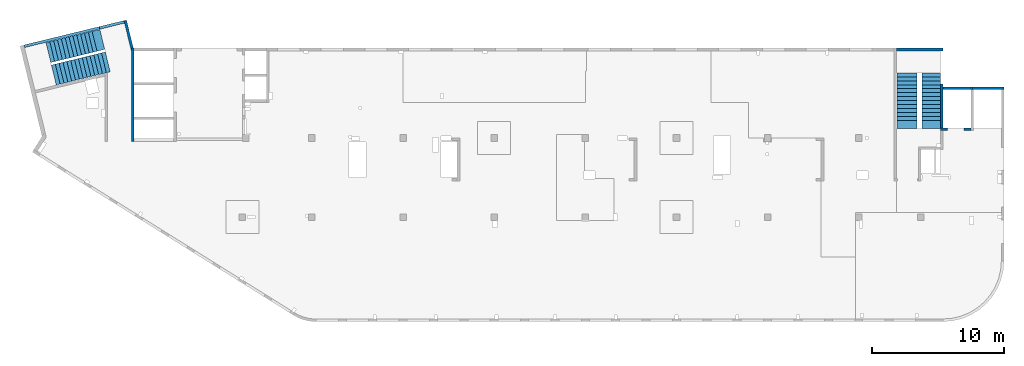
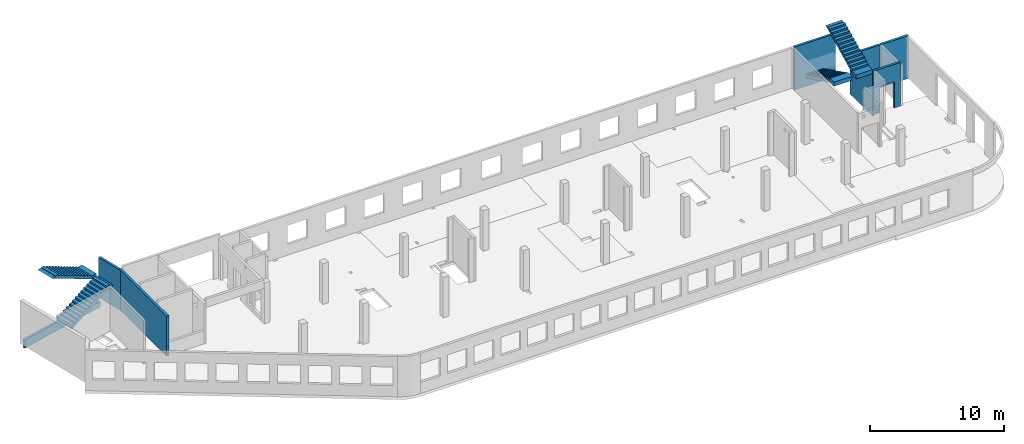
# One storey, part 3 of 6: 8 walls, 4 stairs, 3 openings.
"""IFC4 building model written with IfcOpenShell, lengths in millimetres."""

from ifc_helpers import new_model, entity, si_unit, converted_unit, derived_unit, direction, frame, origin, place, context, subcontext, project, spatial, indexed_curve, outline, extrude, polygons, material, type_object, element, save


model = new_model("IFC4")

# Units and contexts
model_context = context("Model", 3, precision=0.01, world=origin(), true_north=direction((6.12303176911189e-17, 1.0)))
plan_context = context("Plan", 3, precision=0.01, world=origin(), true_north=direction((6.12303176911189e-17, 1.0)))
body_context = subcontext(model_context, "Body", "Model", "MODEL_VIEW")
ifc_project = project(units=[si_unit("LENGTHUNIT", "METRE", prefix="MILLI"), si_unit("AREAUNIT", "SQUARE_METRE"), si_unit("VOLUMEUNIT", "CUBIC_METRE"), converted_unit("PLANEANGLEUNIT", "DEGREE", entity("IfcRatioMeasure", 0.0174532925199433), si_unit("PLANEANGLEUNIT", "RADIAN"), dimensions=[0, 0, 0, 0, 0, 0, 0]), si_unit("MASSUNIT", "GRAM", prefix="KILO"), derived_unit("MASSDENSITYUNIT", [(si_unit("MASSUNIT", "GRAM", prefix="KILO"), 1), (si_unit("LENGTHUNIT", "METRE"), -3)]), derived_unit("MOMENTOFINERTIAUNIT", [(si_unit("LENGTHUNIT", "METRE"), 4)]), si_unit("TIMEUNIT", "SECOND"), si_unit("FREQUENCYUNIT", "HERTZ"), si_unit("THERMODYNAMICTEMPERATUREUNIT", "DEGREE_CELSIUS"), derived_unit("THERMALTRANSMITTANCEUNIT", [(si_unit("MASSUNIT", "GRAM", prefix="KILO"), 1), (si_unit("THERMODYNAMICTEMPERATUREUNIT", "KELVIN"), -1), (si_unit("TIMEUNIT", "SECOND"), -3)]), derived_unit("VOLUMETRICFLOWRATEUNIT", [(si_unit("LENGTHUNIT", "METRE"), 3), (si_unit("TIMEUNIT", "SECOND"), -1)]), derived_unit("MASSFLOWRATEUNIT", [(si_unit("MASSUNIT", "GRAM", prefix="KILO"), 1), (si_unit("TIMEUNIT", "SECOND"), -1)]), derived_unit("ROTATIONALFREQUENCYUNIT", [(si_unit("TIMEUNIT", "SECOND"), -1)]), si_unit("ELECTRICCURRENTUNIT", "AMPERE"), si_unit("ELECTRICVOLTAGEUNIT", "VOLT"), si_unit("POWERUNIT", "WATT"), si_unit("FORCEUNIT", "NEWTON", prefix="KILO"), si_unit("ILLUMINANCEUNIT", "LUX"), si_unit("LUMINOUSFLUXUNIT", "LUMEN"), si_unit("LUMINOUSINTENSITYUNIT", "CANDELA"), derived_unit("USERDEFINED", [(si_unit("MASSUNIT", "GRAM", prefix="KILO"), -1), (si_unit("LENGTHUNIT", "METRE"), -2), (si_unit("TIMEUNIT", "SECOND"), 3), (si_unit("LUMINOUSFLUXUNIT", "LUMEN"), 1)]), derived_unit("LINEARVELOCITYUNIT", [(si_unit("LENGTHUNIT", "METRE"), 1), (si_unit("TIMEUNIT", "SECOND"), -1)]), si_unit("PRESSUREUNIT", "PASCAL"), derived_unit("USERDEFINED", [(si_unit("LENGTHUNIT", "METRE"), -2), (si_unit("MASSUNIT", "GRAM", prefix="KILO"), 1), (si_unit("TIMEUNIT", "SECOND"), -2)]), derived_unit("LINEARFORCEUNIT", [(si_unit("MASSUNIT", "GRAM", prefix="KILO"), 1), (si_unit("LENGTHUNIT", "METRE"), 1), (si_unit("TIMEUNIT", "SECOND"), -2), (si_unit("LENGTHUNIT", "METRE"), -1)]), derived_unit("PLANARFORCEUNIT", [(si_unit("MASSUNIT", "GRAM", prefix="KILO"), 1), (si_unit("LENGTHUNIT", "METRE"), 1), (si_unit("TIMEUNIT", "SECOND"), -2), (si_unit("LENGTHUNIT", "METRE"), -2)])], contexts=[model_context, plan_context])

# Site, building, storey
site_placement = place(None, origin())
site = spatial("IfcSite", under=ifc_project, at=site_placement, CompositionType="ELEMENT")
building_placement = place(site_placement, origin())
building = spatial("IfcBuilding", under=site, at=building_placement, CompositionType="ELEMENT")
storey_placement = place(building_placement, frame((0.0, 0.0, 8100.0)))
storey = spatial("IfcBuildingStorey", under=building, at=storey_placement, CompositionType="ELEMENT", Elevation=8100.0)

# Wall
ifc_material_1 = material()
wall_type = type_object("IfcWallType", PredefinedType="STANDARD")
wall_1_placement = place(storey_placement, frame((71069.9994506836, 17469.9992263555, -400.0)))
element("IfcWall", 1, at=wall_1_placement, inside=storey, type_object=wall_type, material=ifc_material_1, PredefinedType="NOTDEFINED", context=body_context, shape_type="SweptSolid", body=[
    extrude(outline(indexed_curve([(2500.0008178711, -99.9999999999999), (2500.0008178711, 100.0), (99.9999999999943, 99.9999999999992), (99.9999999999949, -100.000000000001), (2500.0008178711, -99.9999999999999)], self_intersect=False)), origin(), (0.0, 0.0, 1.0), 3900.0),
])

# Wall, opening
wall_2_placement = place(storey_placement, frame((71069.9994506836, 14369.9992263555, -150.0), z_axis=(0.0, 0.0, 1.0), x_axis=(-1.0, 0.0, 0.0)))
wall_2 = element("IfcWall", 2, at=wall_2_placement, inside=storey, type_object=wall_type, material=ifc_material_1, PredefinedType="NOTDEFINED", context=body_context, shape_type="Tessellation", body=[
    polygons([(2299.99918212887, -100.000000000003, 3950.0), (2099.99918212887, -100.000000000001, 3950.0), (-2.4387927500343e-12, -100.000000000001, 3950.0), (-2.4387927500343e-12, -100.000000000001, 0.0), (529.999182128873, -100.000000000001, 0.0), (529.999182128864, -100.000000000001, 2369.99999999805), (1769.99918212887, -99.9999999999989, 2369.99999999804), (1769.99918212887, -99.9999999999989, 0.0), (2299.99918212887, -100.000000000003, 0.0), (2299.99918212887, -100.000000000001, 3650.0), (-3.00376710535355e-12, 99.9999999999968, 3950.0), (2099.99918212887, 99.9999999999989, 3950.0), (2299.99918212887, 99.9999999999989, 3950.0), (2299.99918212887, 99.9999999999989, 3900.0), (2299.99918212887, 99.9999999999989, 0.0), (2099.99918212887, 99.9999999999989, 0.0), (1769.99918212887, 99.9999999999989, 0.0), (1769.99918212887, 99.9999999999989, 2369.99999999805), (529.999182128872, 99.9999999999989, 2369.99999999805), (529.999182128872, 99.9999999999989, 0.0), (-3.00376710535355e-12, 99.9999999999968, 0.0), (-3.00376710535355e-12, 99.9999999999989, 3650.0)], [[[1, 2, 3, 4, 5, 6, 7, 8, 9, 10]], [[11, 12, 13, 14, 15, 16, 17, 18, 19, 20, 21, 22]], [[4, 21, 20, 5]], [[3, 2, 1, 13, 12, 11]], [[4, 3, 11, 22, 21]], [[6, 19, 18, 7]], [[7, 18, 17, 8]], [[19, 6, 5, 20]], [[9, 15, 14, 13, 1, 10]], [[15, 9, 8, 17, 16]]], closed=True),
])
opening_1_placement = place(wall_2_placement, frame((71069.9994506836, 14369.9992263555, 150.0), z_axis=(0.0, 0.0, 1.0), x_axis=(-1.0, 0.0, 0.0)))
element("IfcOpeningElement", 3, at=opening_1_placement, cuts=wall_2, PredefinedType="OPENING", context=body_context, shape_type="SweptSolid", body=[
    extrude(outline(indexed_curve([(-619.999999999998, -1184.99999999902), (620.000000000006, -1184.99999999902), (620.000000000006, 1184.99999999902), (-619.999999999998, 1184.99999999902), (-619.999999999998, -1184.99999999902)], self_intersect=False)), frame((69920.0002685547, 14569.9992263574, 1035.0), z_axis=(0.0, -1.0, 0.0), x_axis=(-1.0, 0.0, 0.0)), (0.0, 0.0, 1.0), 400.000000001943),
])

# Wall, openings
wall_3_placement = place(storey_placement, frame((7600.0002685547, 20499.9998657227, -150.0), z_axis=(0.0, 0.0, 1.0), x_axis=(0.0, -1.0, 0.0)))
wall_3 = element("IfcWall", 4, at=wall_3_placement, inside=storey, type_object=wall_type, material=ifc_material_1, PredefinedType="NOTDEFINED", context=body_context, shape_type="Tessellation", body=[
    polygons([(0.0, -100.000000000001, 0.0), (226.50010582161, -99.9999999999996, 0.0), (7050.0006393668, -99.9999999999996, 0.0), (7050.0006393668, -99.9999999999996, 3650.0), (226.500105821614, -99.9999999999996, 3650.0), (0.0, -100.000000000001, 3650.0), (0.0, 100.0, 0.0), (0.0, 100.0, 3650.0), (200.000000000002, 100.0, 3650.0), (6850.0006393668, 100.0, 3650.0), (7050.0006393668, 99.9999999999993, 3650.0), (7050.0006393668, 100.0, 1200.0), (7050.0006393668, 99.9999999999993, 0.0), (6850.0006393668, 100.0, 0.0), (0.0, 50.6443876577722, 0.0), (0.0, 50.6443876577722, 3650.0), (0.0, 7.9044633377313e-14, 3650.0)], [[[1, 2, 3, 4, 5, 6]], [[7, 8, 9, 10, 11, 12, 13, 14]], [[3, 2, 1, 15, 7, 14, 13]], [[6, 5, 4, 11, 10, 9, 8, 16, 17]], [[1, 6, 17, 16, 8, 7, 15]], [[4, 3, 13, 12, 11]]], closed=True),
])
opening_2_placement = place(wall_3_placement, frame((20499.9998657227, -7600.0002685547, 150.0), z_axis=(0.0, 0.0, 1.0), x_axis=(0.0, 1.0, 0.0)))
element("IfcOpeningElement", 5, at=opening_2_placement, cuts=wall_3, PredefinedType="OPENING", context=body_context, shape_type="SweptSolid", body=[
    extrude(outline(indexed_curve([(-154.999999999993, -154.999999999999), (154.999999999993, -154.999999999999), (154.999999999993, 154.999999999999), (-154.999999999993, 154.999999999999), (-154.999999999993, -154.999999999999)], self_intersect=False)), frame((7500.00026855469, 14359.9998657227, 3655.0), z_axis=(1.0, 0.0, 0.0), x_axis=(0.0, 0.0, -1.0)), (0.0, 0.0, 1.0), 200.000000000962),
])
opening_3_placement = place(wall_3_placement, frame((20499.9998657227, -7600.0002685547, 150.0), z_axis=(0.0, 0.0, 1.0), x_axis=(0.0, 1.0, 0.0)))
element("IfcOpeningElement", 6, at=opening_3_placement, cuts=wall_3, PredefinedType="OPENING", context=body_context, shape_type="SweptSolid", body=[
    extrude(outline(indexed_curve([(-154.999999999993, -154.999999999999), (154.999999999993, -154.999999999999), (154.999999999993, 154.999999999999), (-154.999999999993, 154.999999999999), (-154.999999999993, -154.999999999999)], self_intersect=False)), frame((7500.00026855469, 14799.9998657227, 3655.0), z_axis=(1.0, 0.0, 0.0), x_axis=(0.0, 0.0, -1.0)), (0.0, 0.0, 1.0), 200.000000000962),
])

# Walls
wall_4_placement = place(storey_placement, frame((68870.0002685547, 17779.9992263555, -400.0), z_axis=(0.0, 0.0, 1.0), x_axis=(0.0, -1.0, 0.0)))
element("IfcWall", 7, at=wall_4_placement, inside=storey, type_object=wall_type, material=ifc_material_1, PredefinedType="NOTDEFINED", context=body_context, shape_type="Tessellation", body=[
    polygons([(2.16573425859679e-12, -99.9999999999946, 0.0), (3310.0, -99.9999999999946, 0.0), (3310.0, -99.9999999999946, 249.999999999999), (3310.0, -99.9999999999946, 3900.0), (2.16573425859679e-12, -99.9999999999946, 3900.0), (3310.0, 100.000000000012, 0.0), (410.0, 100.000000000003, 0.0), (210.0, 100.000000000003, 0.0), (2.16573425859679e-12, 100.000000000012, 0.0), (2.16573425859679e-12, 100.000000000012, 3900.0), (3310.0, 100.000000000012, 3900.0)], [[[1, 2, 3, 4, 5]], [[6, 7, 8, 9, 10, 11]], [[2, 1, 9, 8, 7, 6]], [[9, 1, 5, 10]], [[2, 6, 11, 4, 3]], [[5, 4, 11, 10]]], closed=True),
])
wall_5_placement = place(storey_placement, frame((68970.0002685547, 17469.9992263555, -400.0)))
element("IfcWall", 8, at=wall_5_placement, inside=storey, type_object=wall_type, material=ifc_material_1, PredefinedType="NOTDEFINED", context=body_context, shape_type="Tessellation", body=[
    polygons([(6.89939203009021e-12, -100.000000000001, 0.0), (2199.99918212887, -100.000000000001, 0.0), (2199.99918212887, -100.000000000001, 249.999999999999), (2099.99918212888, -100.000000000001, 249.999999999999), (2099.99918212888, -100.000000000001, 3900.0), (6.89939203009021e-12, -100.000000000001, 3900.0), (2199.99918212887, 99.9999999999989, 0.0), (6.28061057235613e-12, 99.9999999999989, 0.0), (6.28061057235613e-12, 99.9999999999989, 3900.0), (2099.99918212888, 99.9999999999989, 3900.0), (2099.99918212888, 99.9999999999989, 249.999999999999), (2199.99918212887, 99.9999999999989, 249.999999999999)], [[[1, 2, 3, 4, 5, 6]], [[7, 8, 9, 10, 11, 12]], [[2, 1, 8, 7]], [[2, 7, 12, 3]], [[5, 4, 11, 10]], [[8, 1, 6, 9]], [[4, 3, 12, 11]], [[6, 5, 10, 9]]], closed=True),
])
wall_6_placement = place(storey_placement, frame((65430.0002685547, 20399.9998657227, -400.0)))
element("IfcWall", 9, at=wall_6_placement, inside=storey, type_object=wall_type, material=ifc_material_1, PredefinedType="NOTDEFINED", context=body_context, shape_type="SweptSolid", body=[
    extrude(outline(indexed_curve([(3539.99999999995, 99.9999999999989), (-3.67073603151997e-13, 99.9999999999989), (3.67073603151997e-13, -99.9999999999989), (3539.99999999995, -99.9999999999989), (3539.99999999995, 99.9999999999989)], self_intersect=False)), origin(), (0.0, 0.0, 1.0), 3900.0),
])
wall_7_placement = place(storey_placement, frame((7033.44218130896, 22609.751914045, -150.0), z_axis=(0.0, 0.0, 1.0), x_axis=(0.236826092990328, -0.971552058141475, 0.0)))
element("IfcWall", 10, at=wall_7_placement, inside=storey, type_object=wall_type, material=ifc_material_1, PredefinedType="NOTDEFINED", context=body_context, shape_type="Tessellation", body=[
    polygons([(-4.33146851719357e-12, -99.9999999999989, 0.0), (2380.28371765147, -99.9999999999995, 0.0), (2380.28371765147, -100.000000000001, 3650.0), (199.999999999998, -100.0, 3650.0), (-4.33146851719357e-12, -99.9999999999989, 3650.0), (-4.33146851719357e-12, -99.9999999999989, 3150.0), (-4.33146851719357e-12, 100.0, 0.0), (-4.33146851719357e-12, 100.0, 3650.0), (2195.90359543113, 99.9999999999989, 3650.0), (2195.90359543113, 99.9999999999989, 0.0), (2160.22707367122, -46.3588648763722, 0.0), (2160.22707367122, -46.3588648763722, 3650.0)], [[[1, 2, 3, 4, 5, 6]], [[7, 8, 9, 10]], [[2, 1, 7, 10, 11]], [[11, 10, 9, 12]], [[1, 6, 5, 8, 7]], [[3, 2, 11, 12]], [[5, 4, 3, 12, 9, 8]]], closed=True),
])
wall_8_placement = place(storey_placement, frame((-618.128763974208, 20641.672451718, -900.0), z_axis=(0.0, 0.0, 1.0), x_axis=(0.971552058141473, 0.236826092990338, 0.0)))
element("IfcWall", 11, at=wall_8_placement, inside=storey, type_object=wall_type, material=ifc_material_1, PredefinedType="NOTDEFINED", context=body_context, shape_type="Tessellation", body=[
    polygons([(0.0, -100.000000000003, -1.08286712929839e-12), (7799.99206966279, -99.9999999999989, -1.08286712929839e-12), (7799.99206966279, -99.9999999999989, 500.000000000004), (5869.9920696628, -100.000000000003, 500.000000000004), (5869.99206966279, -100.000000000003, 750.000000000001), (5.41433564649196e-13, -100.000000000003, 750.000000000001), (7799.99206966279, 99.9999999999989, -1.08286712929839e-12), (1.08286712929839e-12, 99.9999999999989, -1.08286712929839e-12), (0.0, 99.9999999999989, 500.000000000001), (0.0, 99.9999999999989, 750.000000000001), (5869.9920696628, 99.9999999999989, 750.000000000001), (5869.9920696628, 99.9999999999989, 500.000000000004), (7799.99206966279, 99.9999999999989, 500.000000000004)], [[[1, 2, 3, 4, 5, 6]], [[7, 8, 9, 10, 11, 12, 13]], [[2, 1, 8, 7]], [[10, 6, 5, 11]], [[12, 4, 3, 13]], [[4, 12, 11, 5]], [[2, 7, 13, 3]], [[1, 6, 10, 9, 8]]], closed=True),
])

# Stairs
ifc_material_2 = material()
stair_type_1 = type_object("IfcStairType", PredefinedType="HALF_TURN_STAIR")
stair_1_placement = place(storey_placement, origin())
element("IfcStair", 12, at=stair_1_placement, inside=storey, type_object=stair_type_1, material=ifc_material_2, PredefinedType="HALF_TURN_STAIR", context=body_context, shape_type="SweptSolid", body=[
    extrude(outline(indexed_curve([(843.870967741944, -2179.17507067743), (1213.87096774194, -2179.17507067743), (1213.87096774195, -1871.96147517747), (-906.129032258053, 2368.03852482254), (-906.129032258053, 2020.82492932259), (-956.129032258054, 2020.82492932259), (-956.129032258054, 1720.82492932259), (-806.129032258056, 1720.82492932259), (-806.129032258056, 1420.82492932259), (-656.129032258055, 1420.82492932259), (-656.129032258055, 1120.82492932258), (-506.129032258057, 1120.82492932258), (-506.129032258057, 820.824929322583), (-356.129032258056, 820.824929322583), (-356.129032258056, 520.824929322582), (-206.129032258056, 520.824929322582), (-206.129032258056, 220.824929322581), (-56.1290322580552, 220.824929322581), (-56.1290322580552, -79.1750706774201), (93.8709677419453, -79.1750706774201), (93.8709677419453, -379.175070677421), (243.870967741946, -379.175070677421), (243.870967741946, -679.175070677422), (393.870967741944, -679.175070677422), (393.870967741944, -979.175070677423), (543.870967741945, -979.175070677423), (543.870967741945, -1279.17507067742), (693.870967741945, -1279.17507067742), (693.870967741945, -1579.17507067743), (843.870967741944, -1579.17507067743), (843.870967741944, -2179.17507067743)], self_intersect=False)), frame((67360.0002685547, 16609.1742970334, 4713.87096774195), z_axis=(1.0, 0.0, 0.0), x_axis=(0.0, 0.0, -1.0)), (0.0, 0.0, 1.0), 1390.0),
])
stair_type_2 = type_object("IfcStairType", PredefinedType="HALF_TURN_STAIR")
stair_2_placement = place(storey_placement, origin())
element("IfcStair", 13, at=stair_2_placement, inside=storey, type_object=stair_type_2, material=ifc_material_2, PredefinedType="HALF_TURN_STAIR", context=body_context, shape_type="SweptSolid", body=[
    extrude(outline(indexed_curve([(-1961.8142397, -852.000000000003), (-1961.8142397, -1202.0), (-1914.60064420005, -1202.00000000001), (1645.39935579997, 577.999999999996), (2238.18576029999, 577.999999999996), (2238.18576029999, 947.999999999997), (1638.18576030001, 947.999999999997), (1638.18576030001, 797.999999999998), (1338.18576030001, 797.999999999998), (1338.18576030001, 647.999999999998), (1038.18576030001, 647.999999999998), (1038.18576030001, 497.999999999997), (738.185760300008, 497.999999999997), (738.185760300008, 347.999999999997), (438.185760300007, 347.999999999997), (438.185760300007, 197.999999999996), (138.185760300006, 197.999999999996), (138.185760300006, 47.9999999999977), (-161.814239699995, 47.9999999999977), (-161.814239699995, -102.000000000003), (-461.814239699997, -102.000000000003), (-461.814239699997, -252.000000000003), (-761.814239699998, -252.000000000003), (-761.814239699998, -402.000000000002), (-1061.8142397, -402.000000000002), (-1061.8142397, -552.000000000002), (-1361.8142397, -552.000000000002), (-1361.8142397, -702.000000000003), (-1661.8142397, -702.000000000003), (-1661.8142397, -852.000000000003), (-1961.8142397, -852.000000000003)], self_intersect=False)), frame((65450.0002685547, 16668.184986656, 2922.0), z_axis=(-1.0, 0.0, 0.0), x_axis=(0.0, -1.0, 0.0)), (0.0, 0.0, -1.0), 1550.0),
])
stair_type_3 = type_object("IfcStairType", PredefinedType="HALF_TURN_STAIR")
stair_3_placement = place(storey_placement, origin())
element("IfcStair", 14, at=stair_3_placement, inside=storey, type_object=stair_type_3, material=ifc_material_2, PredefinedType="HALF_TURN_STAIR", context=body_context, shape_type="SweptSolid", body=[
    extrude(outline(indexed_curve([(871.999999999999, -2240.93152968505), (1242.0, -2240.93152968505), (1241.99999999999, -1934.66369491541), (-878.000000000013, 2305.33630508466), (-878.000000000014, 1958.12270958467), (-927.999999999998, 1958.12270958467), (-927.999999999997, 1658.12270958467), (-777.999999999997, 1658.12270958467), (-777.999999999998, 1358.12270958466), (-627.999999999998, 1358.12270958466), (-627.999999999997, 1058.12270958466), (-477.999999999998, 1058.12270958466), (-477.999999999997, 758.122709584654), (-327.999999999997, 758.122709584654), (-327.999999999998, 458.122709584651), (-177.999999999998, 458.12270958465), (-177.999999999999, 158.122709584646), (-27.9999999999984, 158.122709584646), (-27.9999999999997, -141.877290415355), (122.000000000001, -141.877290415355), (122.000000000002, -441.877290415358), (272.0, -441.877290415359), (272.000000000001, -741.877290415361), (421.999999999999, -741.877290415362), (422.0, -1041.87729041536), (572.000000000001, -1041.87729041537), (571.999999999999, -1341.87729041537), (722.0, -1341.87729041537), (721.999999999999, -1641.87729041537), (871.999999999999, -1641.87729041537), (871.999999999999, -2240.93152968505)], self_intersect=False)), frame((3302.28089700649, 19878.4146408221, 4742.0), z_axis=(-0.236826092990341, 0.971552058141472, 0.0), x_axis=(0.0, 0.0, -1.0)), (0.0, 0.0, 1.0), 1550.00000000006),
])
stair_type_4 = type_object("IfcStairType", PredefinedType="HALF_TURN_STAIR")
stair_4_placement = place(storey_placement, origin())
element("IfcStair", 15, at=stair_4_placement, inside=storey, type_object=stair_type_4, material=ifc_material_2, PredefinedType="HALF_TURN_STAIR", context=body_context, shape_type="SweptSolid", body=[
    extrude(outline(indexed_curve([(-2082.95035407268, -903.749999999996), (-2082.95035407268, -1253.75), (-2035.73675857273, -1253.75), (1524.26324142725, 526.24999999998), (2117.04171559009, 526.249999999978), (2117.0417155901, 776.249999999973), (1817.04964592736, 776.249999999975), (1817.04964592736, 896.250000000011), (1517.04964592735, 896.250000000011), (1517.04964592735, 746.25000000001), (1217.04964592735, 746.25000000001), (1217.04964592735, 596.250000000009), (917.049645927346, 596.250000000009), (917.049645927346, 446.250000000009), (617.049645927341, 446.250000000009), (617.049645927341, 296.250000000008), (317.049645927337, 296.250000000008), (317.049645927336, 146.250000000008), (17.0496459273321, 146.250000000008), (17.049645927331, -3.74999999999277), (-282.950354072672, -3.74999999999277), (-282.950354072672, -153.749999999993), (-582.950354072675, -153.749999999993), (-582.950354072676, -303.749999999994), (-882.950354072678, -303.749999999994), (-882.950354072679, -453.749999999994), (-1182.95035407268, -453.749999999994), (-1182.95035407268, -603.749999999995), (-1482.95035407268, -603.749999999995), (-1482.95035407268, -753.749999999996), (-1782.95035407268, -753.749999999996), (-1782.95035407268, -903.749999999996), (-2082.95035407268, -903.749999999996)], self_intersect=False)), frame((3838.00311465482, 18207.7609824159, 2973.75000000001), z_axis=(0.236826092990333, -0.971552058141474, 0.0), x_axis=(0.971552058141474, 0.236826092990333, 0.0)), (0.0, 0.0, -1.0), 1550.0),
])

save(model, "model.ifc")
